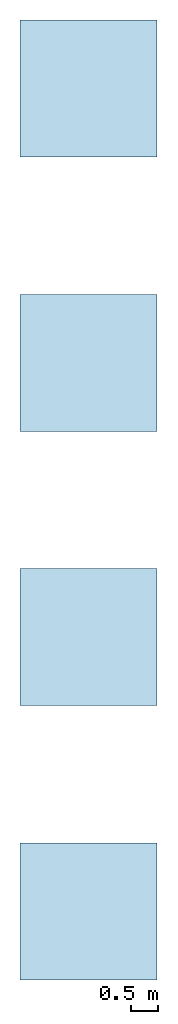
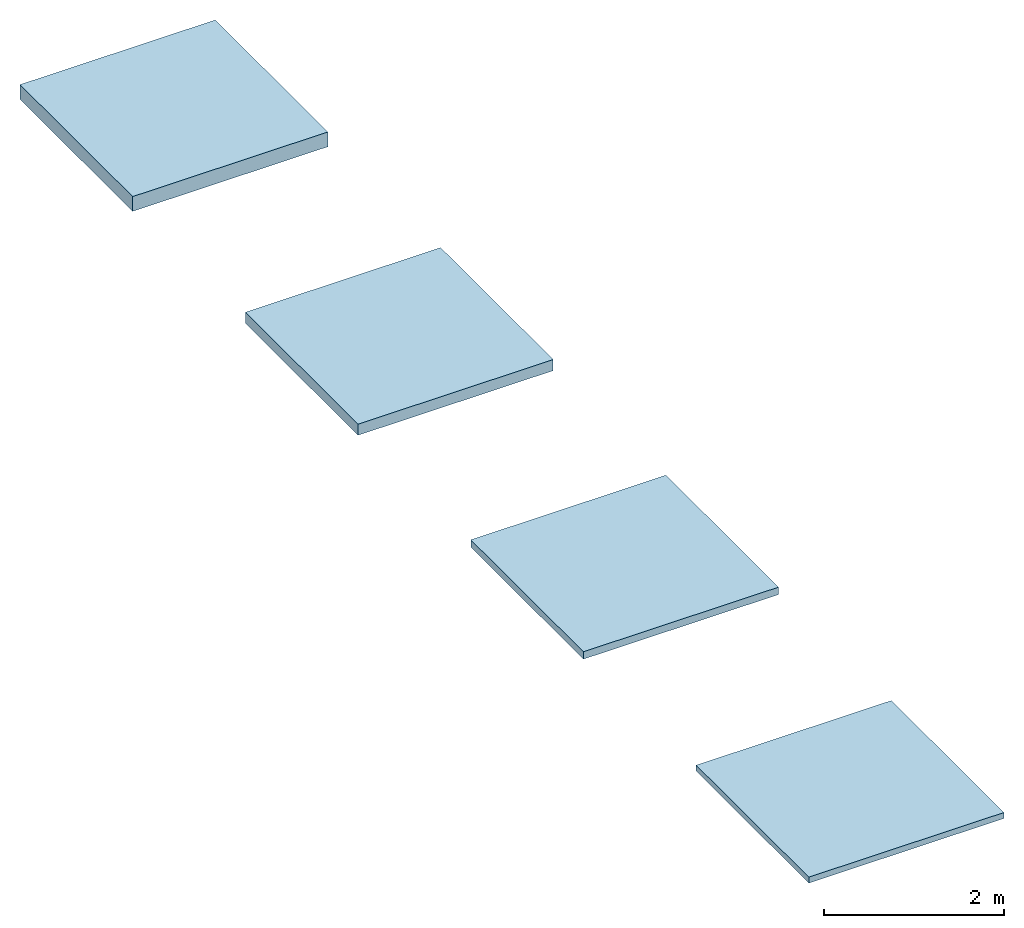
# Not in any storey: 4 slabs.
"""IFC2X3 building model written with IfcOpenShell, lengths in millimetres."""

from ifc_helpers import new_model, si_unit, frame, frame_2d, origin, origin_with_axes, origin_2d, place, context, project, spatial, rectangle, extrude, material, layer, layer_set, layer_usage, type_object, element, save


model = new_model("IFC2X3")

# Units and contexts
model_context = context("Model", 3, precision=1e-05, world=origin())
plan_context = context("Plan", 2, precision=1e-05, world=origin_2d())
ifc_project = project(units=[si_unit("LENGTHUNIT", "METRE", prefix="MILLI"), si_unit("AREAUNIT", "SQUARE_METRE"), si_unit("VOLUMEUNIT", "CUBIC_METRE"), si_unit("SOLIDANGLEUNIT", "STERADIAN"), si_unit("PLANEANGLEUNIT", "RADIAN"), si_unit("MASSUNIT", "GRAM"), si_unit("TIMEUNIT", "SECOND"), si_unit("THERMODYNAMICTEMPERATUREUNIT", "DEGREE_CELSIUS"), si_unit("LUMINOUSINTENSITYUNIT", "LUMEN")], contexts=[model_context, plan_context])

# Site, building
site_placement = place(None, frame((0.0, 0.0, 0.0), z_axis=(0.0, 1.0, 0.0), x_axis=(0.0, 0.0, 1.0)))
site = spatial("IfcSite", under=ifc_project, at=site_placement, CompositionType="ELEMENT")
building_placement = place(site_placement, frame((0.0, 0.0, 0.0), z_axis=(0.0, 1.0, 0.0), x_axis=(0.0, 0.0, 1.0)))
building = spatial("IfcBuilding", under=site, at=building_placement, Name="Default building", CompositionType="ELEMENT")

# Slabs
ifc_material_1 = material()
ifc_layer_1 = layer(ifc_material_1, 80.0, ventilated=False)
ifc_layer_set_1 = layer_set([ifc_layer_1])
ifc_layer_usage_1 = layer_usage(ifc_layer_set_1, "AXIS3", "NEGATIVE", 0.0)
slab_type_1 = type_object("IfcSlabType", PredefinedType="FLOOR", material=ifc_layer_set_1)
slab_1_placement = place(None, origin())
element("IfcSlab", 1, at=slab_1_placement, inside=building, type_object=slab_type_1, material=ifc_layer_usage_1, PredefinedType="FLOOR", context=model_context, shape_type="SweptSolid", body=[
    extrude(rectangle(XDim=2500.0, YDim=2500.0, at=frame_2d((1250.0, 1250.0))), origin_with_axes(), (0.0, 0.0, 1.0), 80.0),
])
ifc_material_2 = material()
ifc_layer_2 = layer(ifc_material_2, 100.0, ventilated=False)
ifc_layer_set_2 = layer_set([ifc_layer_2])
ifc_layer_usage_2 = layer_usage(ifc_layer_set_2, "AXIS3", "NEGATIVE", 0.0)
slab_type_2 = type_object("IfcSlabType", PredefinedType="FLOOR", material=ifc_layer_set_2)
slab_2_placement = place(None, frame((0.0, 5000.0, 0.0)))
element("IfcSlab", 2, at=slab_2_placement, inside=building, type_object=slab_type_2, material=ifc_layer_usage_2, PredefinedType="FLOOR", context=model_context, shape_type="SweptSolid", body=[
    extrude(rectangle(XDim=2500.0, YDim=2500.0, at=frame_2d((1250.0, 1250.0))), origin_with_axes(), (0.0, 0.0, 1.0), 100.0),
])
ifc_material_3 = material()
ifc_layer_3 = layer(ifc_material_3, 150.0, ventilated=False)
ifc_layer_set_3 = layer_set([ifc_layer_3])
ifc_layer_usage_3 = layer_usage(ifc_layer_set_3, "AXIS3", "NEGATIVE", 0.0)
slab_type_3 = type_object("IfcSlabType", PredefinedType="FLOOR", material=ifc_layer_set_3)
slab_3_placement = place(None, frame((0.0, 10000.0, 0.0)))
element("IfcSlab", 3, at=slab_3_placement, inside=building, type_object=slab_type_3, material=ifc_layer_usage_3, PredefinedType="FLOOR", context=model_context, shape_type="SweptSolid", body=[
    extrude(rectangle(XDim=2500.0, YDim=2500.0, at=frame_2d((1250.0, 1250.0))), origin_with_axes(), (0.0, 0.0, 1.0), 150.0),
])
ifc_material_4 = material()
ifc_layer_4 = layer(ifc_material_4, 200.0, ventilated=False)
ifc_layer_set_4 = layer_set([ifc_layer_4])
ifc_layer_usage_4 = layer_usage(ifc_layer_set_4, "AXIS3", "NEGATIVE", 0.0)
slab_type_4 = type_object("IfcSlabType", PredefinedType="FLOOR", material=ifc_layer_set_4)
slab_4_placement = place(None, frame((0.0, 15000.0, 0.0)))
element("IfcSlab", 4, at=slab_4_placement, inside=building, type_object=slab_type_4, material=ifc_layer_usage_4, PredefinedType="FLOOR", context=model_context, shape_type="SweptSolid", body=[
    extrude(rectangle(XDim=2500.0, YDim=2500.0, at=frame_2d((1250.0, 1250.0))), origin_with_axes(), (0.0, 0.0, 1.0), 200.0),
])

save(model, "model.ifc")
